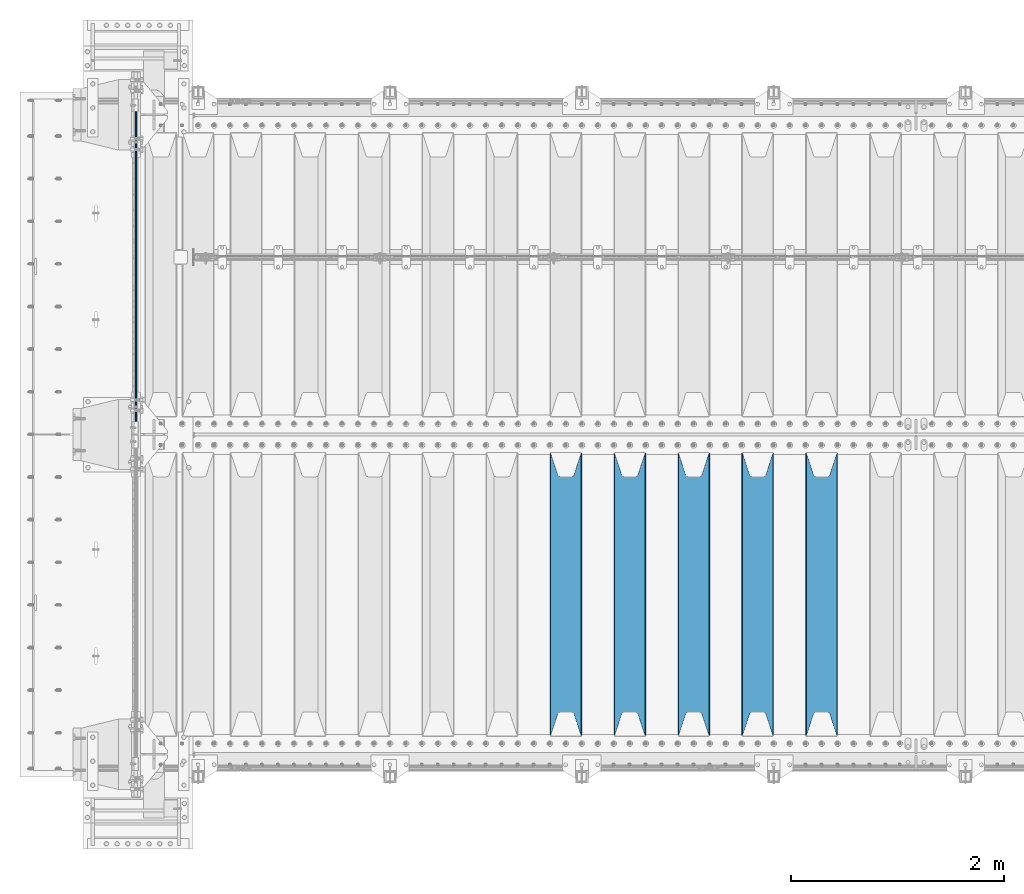
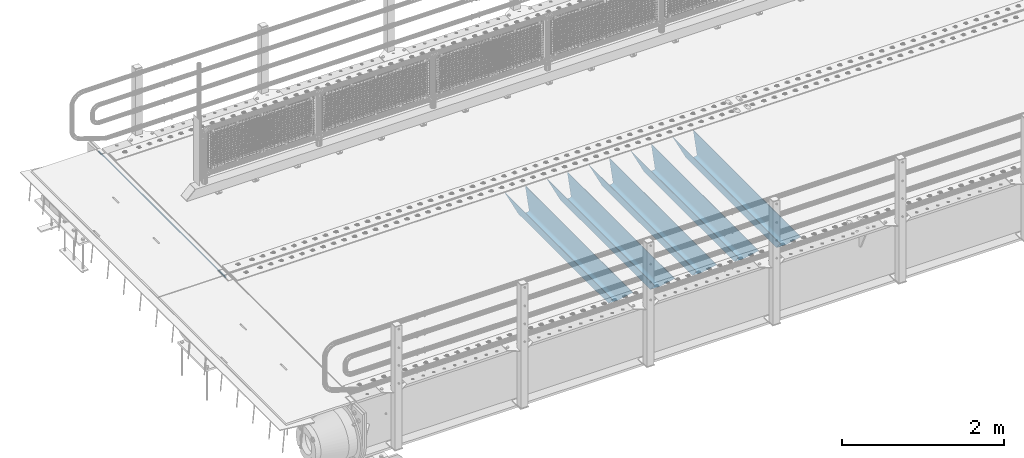
# One storey, part 112 of 242: 6 beams.
"""IFC2X3 building model written with IfcOpenShell, lengths in millimetres."""

from ifc_helpers import new_model, si_unit, frame, origin_with_axes, place, context, subcontext, project, spatial, faceted_brep, material, type_object, element, save


model = new_model("IFC2X3")

# Units and contexts
model_context = context("Model", 3, precision=1e-05, world=origin_with_axes())
body_context = subcontext(model_context, "Body", "Model", "MODEL_VIEW")
ifc_project = project(units=[si_unit("LENGTHUNIT", "METRE", prefix="MILLI"), si_unit("AREAUNIT", "SQUARE_METRE"), si_unit("VOLUMEUNIT", "CUBIC_METRE"), si_unit("MASSUNIT", "GRAM", prefix="KILO"), si_unit("TIMEUNIT", "SECOND"), si_unit("PLANEANGLEUNIT", "RADIAN"), si_unit("SOLIDANGLEUNIT", "STERADIAN"), si_unit("THERMODYNAMICTEMPERATUREUNIT", "DEGREE_CELSIUS"), si_unit("LUMINOUSINTENSITYUNIT", "LUMEN")], contexts=[model_context])

# Site, building, storey
site_placement = place(None, origin_with_axes())
site = spatial("IfcSite", under=ifc_project, at=site_placement, CompositionType="ELEMENT")
building_placement = place(site_placement, origin_with_axes())
building = spatial("IfcBuilding", under=site, at=building_placement, Name="Standard", CompositionType="ELEMENT")
storey_placement = place(building_placement, origin_with_axes())
storey = spatial("IfcBuildingStorey", under=building, at=storey_placement, Name="Undefined", CompositionType="ELEMENT", Elevation=0.0)

# Beams
ifc_material = material(Name="STEEL/S355N")
beam_type_1 = type_object("IfcBeamType", Name="D20", PredefinedType="NOTDEFINED")
beam_1_placement = place(storey_placement, frame((-42485.0, -20995.0, -25.9999999971316), z_axis=(0.0, 0.0, 1.0), x_axis=(0.0, 1.0, 0.0)))
element("IfcBeam", 1, at=beam_1_placement, inside=storey, type_object=beam_type_1, material=ifc_material, ObjectType="D20", context=body_context, shape_type="Brep", body=[
    faceted_brep([(0.0, -10.0, 0.0), (0.0, -7.07106781186303, -7.07106781186548), (3145.0, -7.07106781186303, -7.07106781186548), (3145.0, -10.0, 0.0), (0.0, 0.0, -10.0), (3145.0, 0.0, -10.0), (0.0, 7.07106781186303, -7.07106781186547), (3145.0, 7.07106781186303, -7.07106781186547), (0.0, 10.0, 0.0), (3145.0, 10.0, 0.0), (0.0, 7.07106781186303, 7.07106781186548), (3145.0, 7.07106781186303, 7.07106781186548), (0.0, 0.0, 10.0), (3145.0, 0.0, 10.0), (0.0, -7.07106781186303, 7.07106781186548), (3145.0, -7.07106781186303, 7.07106781186548)], [[[0, 1, 2, 3]], [[1, 4, 5, 2]], [[4, 6, 7, 5]], [[6, 8, 9, 7]], [[8, 10, 11, 9]], [[10, 12, 13, 11]], [[12, 14, 15, 13]], [[14, 0, 3, 15]], [[5, 7, 9, 11, 13, 15, 3, 2]], [[14, 12, 10, 8, 6, 4, 1, 0]]]),
])
beam_type_2 = type_object("IfcBeamType", PredefinedType="NOTDEFINED")
beam_2_placement = place(storey_placement, frame((-36050.0, -23825.0, -115.0), z_axis=(0.0, 0.0, 1.0), x_axis=(0.0, 1.0, 0.0)))
element("IfcBeam", 2, at=beam_2_placement, inside=storey, type_object=beam_type_2, material=ifc_material, context=body_context, shape_type="Brep", body=[
    faceted_brep([(0.0, 150.0, 115.0), (0.0, 143.689999999999, 115.0), (2650.00000000297, 143.689999999999, 115.0), (2650.00000000297, 150.0, 115.0), (2650.00000000297, 142.059565218402, 110.000000003099), (2650.00000000297, 148.369565218403, 110.000000003099), (2441.90079219209, -80.1103600731112, -98.0992078077845), (2437.7588105432, -77.5672621345584, -102.241189456673), (2434.06523489747, -74.4080125315522, -105.934765102404), (2430.91086095089, -70.710272125576, -109.089139048974), (2428.37322971128, -66.5649389910068, -111.626770288588), (2426.51472138055, -62.0739139532889, -113.485278619323), (2425.38102192092, -57.3475956567672, -114.618978078955), (2424.99999999987, -52.5021667386536, -115.0), (2424.99999999987, 52.5021667386536, -115.0), (2425.38102192092, 57.3475956567672, -114.618978078955), (2426.51472138055, 62.0739139532889, -113.485278619323), (2428.37322971128, 66.5649389910068, -111.626770288588), (2430.91086095089, 70.710272125576, -109.089139048974), (2434.06523489747, 74.4080125315522, -105.934765102404), (2437.7588105432, 77.5672621345584, -102.241189456673), (2441.90079219209, 80.1103600731112, -98.0992078077846), (2446.38936140511, 81.9747917625791, -93.6106385947584), (2448.2494850041, 76.2713538057251, -91.7505149957729), (2444.62967112262, 74.76777986261, -95.3703288772456), (2441.28936334126, 72.7168944282894, -98.710636658607), (2438.31067330438, 70.1691124903846, -101.689326695487), (2435.76682334747, 67.1870637758839, -104.233176652398), (2433.72034654133, 63.8440531834895, -106.279653458539), (2432.22154950042, 60.222258798236, -107.778450499454), (2431.30727574265, 56.4107117849089, -108.692724257221), (2430.99999999987, 52.5031078186876, -109.0), (2430.99999999987, -52.5031078186876, -109.0), (2431.30727574265, -56.4107117849089, -108.692724257221), (2432.22154950042, -60.222258798236, -107.778450499454), (2433.72034654133, -63.8440531834895, -106.279653458539), (2435.76682334747, -67.1870637758839, -104.233176652398), (2438.31067330438, -70.1691124903846, -101.689326695487), (2441.28936334126, -72.7168944282894, -98.7106366586071), (2444.62967112262, -74.76777986261, -95.3703288772457), (2448.2494850041, -76.2713538057251, -91.7505149957729), (2650.00000000297, -142.059565218402, 110.000000003099), (2650.00000000297, -148.369565218403, 110.000000003099), (2446.38936140511, -81.9747917625791, -93.6106385947584), (2650.00000000297, -143.689999999999, 115.0), (2650.00000000297, -150.0, 115.0), (0.0, -143.689999999999, 115.0), (0.0, -150.0, 115.0), (0.0, -148.369565218261, 110.000000002669), (203.610638597427, -81.9747917625791, -93.6106385947584), (208.099207810454, -80.1103600731112, -98.0992078077845), (212.241189459342, -77.5672621345584, -102.241189456673), (215.934765105074, -74.4080125315522, -105.934765102404), (219.089139051644, -70.710272125576, -109.089139048974), (221.626770291256, -66.5649389910068, -111.626770288588), (223.485278621993, -62.0739139532889, -113.485278619323), (224.618978081624, -57.3475956567672, -114.618978078955), (225.00000000267, -52.5021667386536, -115.0), (225.00000000267, 52.5021667386536, -115.0), (224.618978081624, 57.3475956567672, -114.618978078955), (223.485278621993, 62.0739139532889, -113.485278619323), (221.626770291256, 66.5649389910068, -111.626770288588), (219.089139051644, 70.710272125576, -109.089139048974), (215.934765105074, 74.4080125315522, -105.934765102404), (212.241189459342, 77.5672621345584, -102.241189456673), (208.099207810454, 80.1103600731112, -98.0992078077846), (203.610638597427, 81.9747917625791, -93.6106385947584), (0.0, 148.369565218261, 110.000000002669), (0.0, 142.05956521826, 110.000000002669), (201.750514998443, 76.2713538057251, -91.7505149957729), (205.370328879915, 74.76777986261, -95.3703288772456), (208.710636661275, 72.7168944282894, -98.710636658607), (211.689326698157, 70.1691124903846, -101.689326695487), (214.233176655067, 67.1870637758839, -104.233176652398), (216.279653461206, 63.8440531834895, -106.279653458539), (217.778450502123, 60.222258798236, -107.778450499454), (218.69272425989, 56.4107117849089, -108.692724257221), (219.00000000267, 52.5031078186876, -109.0), (219.00000000267, -52.5031078186876, -109.0), (218.69272425989, -56.4107117849089, -108.692724257221), (217.778450502123, -60.222258798236, -107.778450499454), (216.279653461206, -63.8440531834895, -106.279653458539), (214.233176655067, -67.1870637758839, -104.233176652398), (211.689326698157, -70.1691124903846, -101.689326695487), (208.710636661275, -72.7168944282894, -98.7106366586071), (205.370328879915, -74.76777986261, -95.3703288772457), (201.750514998443, -76.2713538057251, -91.7505149957729), (0.0, -142.05956521826, 110.000000002669)], [[[0, 1, 2, 3]], [[3, 2, 4, 5]], [[6, 7, 8, 9, 10, 11, 12, 13, 14, 15, 16, 17, 18, 19, 20, 21, 22, 5, 4, 23, 24, 25, 26, 27, 28, 29, 30, 31, 32, 33, 34, 35, 36, 37, 38, 39, 40, 41, 42, 43]], [[44, 45, 42, 41]], [[46, 47, 45, 44]], [[43, 42, 45, 47, 48, 49]], [[6, 43, 49, 50]], [[7, 6, 50, 51]], [[8, 7, 51, 52]], [[9, 8, 52, 53]], [[10, 9, 53, 54]], [[11, 10, 54, 55]], [[12, 11, 55, 56]], [[13, 12, 56, 57]], [[14, 13, 57, 58]], [[15, 14, 58, 59]], [[16, 15, 59, 60]], [[17, 16, 60, 61]], [[18, 17, 61, 62]], [[19, 18, 62, 63]], [[20, 19, 63, 64]], [[21, 20, 64, 65]], [[22, 21, 65, 66]], [[0, 3, 5, 22, 66, 67]], [[1, 0, 67, 68]], [[23, 4, 2, 1, 68, 69]], [[24, 23, 69, 70]], [[25, 24, 70, 71]], [[26, 25, 71, 72]], [[27, 26, 72, 73]], [[28, 27, 73, 74]], [[29, 28, 74, 75]], [[30, 29, 75, 76]], [[31, 30, 76, 77]], [[32, 31, 77, 78]], [[33, 32, 78, 79]], [[34, 33, 79, 80]], [[35, 34, 80, 81]], [[36, 35, 81, 82]], [[37, 36, 82, 83]], [[38, 37, 83, 84]], [[39, 38, 84, 85]], [[40, 39, 85, 86]], [[46, 44, 41, 40, 86, 87]], [[47, 46, 87, 48]], [[86, 85, 84, 83, 82, 81, 80, 79, 78, 77, 76, 75, 74, 73, 72, 71, 70, 69, 68, 67, 66, 65, 64, 63, 62, 61, 60, 59, 58, 57, 56, 55, 54, 53, 52, 51, 50, 49, 48, 87]]]),
])
beam_3_placement = place(storey_placement, frame((-36650.0, -23825.0, -115.0), z_axis=(0.0, 0.0, 1.0), x_axis=(0.0, 1.0, 0.0)))
element("IfcBeam", 3, at=beam_3_placement, inside=storey, type_object=beam_type_2, material=ifc_material, context=body_context, shape_type="Brep", body=[
    faceted_brep([(0.0, 150.0, 115.0), (0.0, 143.689999999999, 115.0), (2650.00000000297, 143.689999999999, 115.0), (2650.00000000297, 150.0, 115.0), (2650.00000000297, 142.059565218402, 110.000000003099), (2650.00000000297, 148.369565218403, 110.000000003099), (2441.90079219209, -80.1103600731112, -98.0992078077845), (2437.7588105432, -77.5672621345584, -102.241189456673), (2434.06523489747, -74.4080125315522, -105.934765102404), (2430.91086095089, -70.710272125576, -109.089139048974), (2428.37322971128, -66.5649389910068, -111.626770288588), (2426.51472138055, -62.0739139532889, -113.485278619323), (2425.38102192092, -57.3475956567672, -114.618978078955), (2424.99999999987, -52.5021667386536, -115.0), (2424.99999999987, 52.5021667386536, -115.0), (2425.38102192092, 57.3475956567672, -114.618978078955), (2426.51472138055, 62.0739139532889, -113.485278619323), (2428.37322971128, 66.5649389910068, -111.626770288588), (2430.91086095089, 70.710272125576, -109.089139048974), (2434.06523489747, 74.4080125315522, -105.934765102404), (2437.7588105432, 77.5672621345584, -102.241189456673), (2441.90079219209, 80.1103600731112, -98.0992078077846), (2446.38936140511, 81.9747917625791, -93.6106385947584), (2448.2494850041, 76.2713538057251, -91.7505149957729), (2444.62967112262, 74.76777986261, -95.3703288772456), (2441.28936334126, 72.7168944282894, -98.710636658607), (2438.31067330438, 70.1691124903846, -101.689326695487), (2435.76682334747, 67.1870637758839, -104.233176652398), (2433.72034654133, 63.8440531834895, -106.279653458539), (2432.22154950042, 60.222258798236, -107.778450499454), (2431.30727574265, 56.4107117849089, -108.692724257221), (2430.99999999987, 52.5031078186876, -109.0), (2430.99999999987, -52.5031078186876, -109.0), (2431.30727574265, -56.4107117849089, -108.692724257221), (2432.22154950042, -60.222258798236, -107.778450499454), (2433.72034654133, -63.8440531834895, -106.279653458539), (2435.76682334747, -67.1870637758839, -104.233176652398), (2438.31067330438, -70.1691124903846, -101.689326695487), (2441.28936334126, -72.7168944282894, -98.7106366586071), (2444.62967112262, -74.76777986261, -95.3703288772457), (2448.2494850041, -76.2713538057251, -91.7505149957729), (2650.00000000297, -142.059565218402, 110.000000003099), (2650.00000000297, -148.369565218403, 110.000000003099), (2446.38936140511, -81.9747917625791, -93.6106385947584), (2650.00000000297, -143.689999999999, 115.0), (2650.00000000297, -150.0, 115.0), (0.0, -143.689999999999, 115.0), (0.0, -150.0, 115.0), (0.0, -148.369565218261, 110.000000002669), (203.610638597427, -81.9747917625791, -93.6106385947584), (208.099207810454, -80.1103600731112, -98.0992078077845), (212.241189459342, -77.5672621345584, -102.241189456673), (215.934765105074, -74.4080125315522, -105.934765102404), (219.089139051644, -70.710272125576, -109.089139048974), (221.626770291256, -66.5649389910068, -111.626770288588), (223.485278621993, -62.0739139532889, -113.485278619323), (224.618978081624, -57.3475956567672, -114.618978078955), (225.00000000267, -52.5021667386536, -115.0), (225.00000000267, 52.5021667386536, -115.0), (224.618978081624, 57.3475956567672, -114.618978078955), (223.485278621993, 62.0739139532889, -113.485278619323), (221.626770291256, 66.5649389910068, -111.626770288588), (219.089139051644, 70.710272125576, -109.089139048974), (215.934765105074, 74.4080125315522, -105.934765102404), (212.241189459342, 77.5672621345584, -102.241189456673), (208.099207810454, 80.1103600731112, -98.0992078077846), (203.610638597427, 81.9747917625791, -93.6106385947584), (0.0, 148.369565218261, 110.000000002669), (0.0, 142.05956521826, 110.000000002669), (201.750514998443, 76.2713538057251, -91.7505149957729), (205.370328879915, 74.76777986261, -95.3703288772456), (208.710636661275, 72.7168944282894, -98.710636658607), (211.689326698157, 70.1691124903846, -101.689326695487), (214.233176655067, 67.1870637758839, -104.233176652398), (216.279653461206, 63.8440531834895, -106.279653458539), (217.778450502123, 60.222258798236, -107.778450499454), (218.69272425989, 56.4107117849089, -108.692724257221), (219.00000000267, 52.5031078186876, -109.0), (219.00000000267, -52.5031078186876, -109.0), (218.69272425989, -56.4107117849089, -108.692724257221), (217.778450502123, -60.222258798236, -107.778450499454), (216.279653461206, -63.8440531834895, -106.279653458539), (214.233176655067, -67.1870637758839, -104.233176652398), (211.689326698157, -70.1691124903846, -101.689326695487), (208.710636661275, -72.7168944282894, -98.7106366586071), (205.370328879915, -74.76777986261, -95.3703288772457), (201.750514998443, -76.2713538057251, -91.7505149957729), (0.0, -142.05956521826, 110.000000002669)], [[[0, 1, 2, 3]], [[3, 2, 4, 5]], [[6, 7, 8, 9, 10, 11, 12, 13, 14, 15, 16, 17, 18, 19, 20, 21, 22, 5, 4, 23, 24, 25, 26, 27, 28, 29, 30, 31, 32, 33, 34, 35, 36, 37, 38, 39, 40, 41, 42, 43]], [[44, 45, 42, 41]], [[46, 47, 45, 44]], [[43, 42, 45, 47, 48, 49]], [[6, 43, 49, 50]], [[7, 6, 50, 51]], [[8, 7, 51, 52]], [[9, 8, 52, 53]], [[10, 9, 53, 54]], [[11, 10, 54, 55]], [[12, 11, 55, 56]], [[13, 12, 56, 57]], [[14, 13, 57, 58]], [[15, 14, 58, 59]], [[16, 15, 59, 60]], [[17, 16, 60, 61]], [[18, 17, 61, 62]], [[19, 18, 62, 63]], [[20, 19, 63, 64]], [[21, 20, 64, 65]], [[22, 21, 65, 66]], [[0, 3, 5, 22, 66, 67]], [[1, 0, 67, 68]], [[23, 4, 2, 1, 68, 69]], [[24, 23, 69, 70]], [[25, 24, 70, 71]], [[26, 25, 71, 72]], [[27, 26, 72, 73]], [[28, 27, 73, 74]], [[29, 28, 74, 75]], [[30, 29, 75, 76]], [[31, 30, 76, 77]], [[32, 31, 77, 78]], [[33, 32, 78, 79]], [[34, 33, 79, 80]], [[35, 34, 80, 81]], [[36, 35, 81, 82]], [[37, 36, 82, 83]], [[38, 37, 83, 84]], [[39, 38, 84, 85]], [[40, 39, 85, 86]], [[46, 44, 41, 40, 86, 87]], [[47, 46, 87, 48]], [[86, 85, 84, 83, 82, 81, 80, 79, 78, 77, 76, 75, 74, 73, 72, 71, 70, 69, 68, 67, 66, 65, 64, 63, 62, 61, 60, 59, 58, 57, 56, 55, 54, 53, 52, 51, 50, 49, 48, 87]]]),
])
beam_4_placement = place(storey_placement, frame((-37250.0, -23825.0, -115.0), z_axis=(0.0, 0.0, 1.0), x_axis=(0.0, 1.0, 0.0)))
element("IfcBeam", 4, at=beam_4_placement, inside=storey, type_object=beam_type_2, material=ifc_material, context=body_context, shape_type="Brep", body=[
    faceted_brep([(0.0, 150.0, 115.0), (0.0, 143.689999999999, 115.0), (2650.00000000297, 143.689999999999, 115.0), (2650.00000000297, 150.0, 115.0), (2650.00000000297, 142.059565218402, 110.000000003099), (2650.00000000297, 148.369565218403, 110.000000003099), (2441.90079219209, -80.1103600731112, -98.0992078077845), (2437.7588105432, -77.5672621345584, -102.241189456673), (2434.06523489747, -74.4080125315522, -105.934765102404), (2430.91086095089, -70.710272125576, -109.089139048974), (2428.37322971128, -66.5649389910068, -111.626770288588), (2426.51472138055, -62.0739139532889, -113.485278619323), (2425.38102192092, -57.3475956567672, -114.618978078955), (2424.99999999987, -52.5021667386536, -115.0), (2424.99999999987, 52.5021667386536, -115.0), (2425.38102192092, 57.3475956567672, -114.618978078955), (2426.51472138055, 62.0739139532889, -113.485278619323), (2428.37322971128, 66.5649389910068, -111.626770288588), (2430.91086095089, 70.710272125576, -109.089139048974), (2434.06523489747, 74.4080125315522, -105.934765102404), (2437.7588105432, 77.5672621345584, -102.241189456673), (2441.90079219209, 80.1103600731112, -98.0992078077846), (2446.38936140511, 81.9747917625791, -93.6106385947584), (2448.2494850041, 76.2713538057251, -91.7505149957729), (2444.62967112262, 74.76777986261, -95.3703288772456), (2441.28936334126, 72.7168944282894, -98.710636658607), (2438.31067330438, 70.1691124903846, -101.689326695487), (2435.76682334747, 67.1870637758839, -104.233176652398), (2433.72034654133, 63.8440531834895, -106.279653458539), (2432.22154950042, 60.222258798236, -107.778450499454), (2431.30727574265, 56.4107117849089, -108.692724257221), (2430.99999999987, 52.5031078186876, -109.0), (2430.99999999987, -52.5031078186876, -109.0), (2431.30727574265, -56.4107117849089, -108.692724257221), (2432.22154950042, -60.222258798236, -107.778450499454), (2433.72034654133, -63.8440531834895, -106.279653458539), (2435.76682334747, -67.1870637758839, -104.233176652398), (2438.31067330438, -70.1691124903846, -101.689326695487), (2441.28936334126, -72.7168944282894, -98.7106366586071), (2444.62967112262, -74.76777986261, -95.3703288772457), (2448.2494850041, -76.2713538057251, -91.7505149957729), (2650.00000000297, -142.059565218402, 110.000000003099), (2650.00000000297, -148.369565218403, 110.000000003099), (2446.38936140511, -81.9747917625791, -93.6106385947584), (2650.00000000297, -143.689999999999, 115.0), (2650.00000000297, -150.0, 115.0), (0.0, -143.689999999999, 115.0), (0.0, -150.0, 115.0), (0.0, -148.369565218261, 110.000000002669), (203.610638597427, -81.9747917625791, -93.6106385947584), (208.099207810454, -80.1103600731112, -98.0992078077845), (212.241189459342, -77.5672621345584, -102.241189456673), (215.934765105074, -74.4080125315522, -105.934765102404), (219.089139051644, -70.710272125576, -109.089139048974), (221.626770291256, -66.5649389910068, -111.626770288588), (223.485278621993, -62.0739139532889, -113.485278619323), (224.618978081624, -57.3475956567672, -114.618978078955), (225.00000000267, -52.5021667386536, -115.0), (225.00000000267, 52.5021667386536, -115.0), (224.618978081624, 57.3475956567672, -114.618978078955), (223.485278621993, 62.0739139532889, -113.485278619323), (221.626770291256, 66.5649389910068, -111.626770288588), (219.089139051644, 70.710272125576, -109.089139048974), (215.934765105074, 74.4080125315522, -105.934765102404), (212.241189459342, 77.5672621345584, -102.241189456673), (208.099207810454, 80.1103600731112, -98.0992078077846), (203.610638597427, 81.9747917625791, -93.6106385947584), (0.0, 148.369565218261, 110.000000002669), (0.0, 142.05956521826, 110.000000002669), (201.750514998443, 76.2713538057251, -91.7505149957729), (205.370328879915, 74.76777986261, -95.3703288772456), (208.710636661275, 72.7168944282894, -98.710636658607), (211.689326698157, 70.1691124903846, -101.689326695487), (214.233176655067, 67.1870637758839, -104.233176652398), (216.279653461206, 63.8440531834895, -106.279653458539), (217.778450502123, 60.222258798236, -107.778450499454), (218.69272425989, 56.4107117849089, -108.692724257221), (219.00000000267, 52.5031078186876, -109.0), (219.00000000267, -52.5031078186876, -109.0), (218.69272425989, -56.4107117849089, -108.692724257221), (217.778450502123, -60.222258798236, -107.778450499454), (216.279653461206, -63.8440531834895, -106.279653458539), (214.233176655067, -67.1870637758839, -104.233176652398), (211.689326698157, -70.1691124903846, -101.689326695487), (208.710636661275, -72.7168944282894, -98.7106366586071), (205.370328879915, -74.76777986261, -95.3703288772457), (201.750514998443, -76.2713538057251, -91.7505149957729), (0.0, -142.05956521826, 110.000000002669)], [[[0, 1, 2, 3]], [[3, 2, 4, 5]], [[6, 7, 8, 9, 10, 11, 12, 13, 14, 15, 16, 17, 18, 19, 20, 21, 22, 5, 4, 23, 24, 25, 26, 27, 28, 29, 30, 31, 32, 33, 34, 35, 36, 37, 38, 39, 40, 41, 42, 43]], [[44, 45, 42, 41]], [[46, 47, 45, 44]], [[43, 42, 45, 47, 48, 49]], [[6, 43, 49, 50]], [[7, 6, 50, 51]], [[8, 7, 51, 52]], [[9, 8, 52, 53]], [[10, 9, 53, 54]], [[11, 10, 54, 55]], [[12, 11, 55, 56]], [[13, 12, 56, 57]], [[14, 13, 57, 58]], [[15, 14, 58, 59]], [[16, 15, 59, 60]], [[17, 16, 60, 61]], [[18, 17, 61, 62]], [[19, 18, 62, 63]], [[20, 19, 63, 64]], [[21, 20, 64, 65]], [[22, 21, 65, 66]], [[0, 3, 5, 22, 66, 67]], [[1, 0, 67, 68]], [[23, 4, 2, 1, 68, 69]], [[24, 23, 69, 70]], [[25, 24, 70, 71]], [[26, 25, 71, 72]], [[27, 26, 72, 73]], [[28, 27, 73, 74]], [[29, 28, 74, 75]], [[30, 29, 75, 76]], [[31, 30, 76, 77]], [[32, 31, 77, 78]], [[33, 32, 78, 79]], [[34, 33, 79, 80]], [[35, 34, 80, 81]], [[36, 35, 81, 82]], [[37, 36, 82, 83]], [[38, 37, 83, 84]], [[39, 38, 84, 85]], [[40, 39, 85, 86]], [[46, 44, 41, 40, 86, 87]], [[47, 46, 87, 48]], [[86, 85, 84, 83, 82, 81, 80, 79, 78, 77, 76, 75, 74, 73, 72, 71, 70, 69, 68, 67, 66, 65, 64, 63, 62, 61, 60, 59, 58, 57, 56, 55, 54, 53, 52, 51, 50, 49, 48, 87]]]),
])
beam_5_placement = place(storey_placement, frame((-37850.0, -23825.0, -115.0), z_axis=(0.0, 0.0, 1.0), x_axis=(0.0, 1.0, 0.0)))
element("IfcBeam", 5, at=beam_5_placement, inside=storey, type_object=beam_type_2, material=ifc_material, context=body_context, shape_type="Brep", body=[
    faceted_brep([(0.0, 150.0, 115.0), (0.0, 143.689999999999, 115.0), (2650.00000000297, 143.689999999999, 115.0), (2650.00000000297, 150.0, 115.0), (2650.00000000297, 142.059565218402, 110.000000003099), (2650.00000000297, 148.369565218403, 110.000000003099), (2441.90079219209, -80.1103600731112, -98.0992078077845), (2437.7588105432, -77.5672621345584, -102.241189456673), (2434.06523489747, -74.4080125315522, -105.934765102404), (2430.91086095089, -70.710272125576, -109.089139048974), (2428.37322971128, -66.5649389910068, -111.626770288588), (2426.51472138055, -62.0739139532889, -113.485278619323), (2425.38102192092, -57.3475956567672, -114.618978078955), (2424.99999999987, -52.5021667386536, -115.0), (2424.99999999987, 52.5021667386536, -115.0), (2425.38102192092, 57.3475956567672, -114.618978078955), (2426.51472138055, 62.0739139532889, -113.485278619323), (2428.37322971128, 66.5649389910068, -111.626770288588), (2430.91086095089, 70.710272125576, -109.089139048974), (2434.06523489747, 74.4080125315522, -105.934765102404), (2437.7588105432, 77.5672621345584, -102.241189456673), (2441.90079219209, 80.1103600731112, -98.0992078077846), (2446.38936140511, 81.9747917625791, -93.6106385947584), (2448.2494850041, 76.2713538057251, -91.7505149957729), (2444.62967112262, 74.76777986261, -95.3703288772456), (2441.28936334126, 72.7168944282894, -98.710636658607), (2438.31067330438, 70.1691124903846, -101.689326695487), (2435.76682334747, 67.1870637758839, -104.233176652398), (2433.72034654133, 63.8440531834895, -106.279653458539), (2432.22154950042, 60.222258798236, -107.778450499454), (2431.30727574265, 56.4107117849089, -108.692724257221), (2430.99999999987, 52.5031078186876, -109.0), (2430.99999999987, -52.5031078186876, -109.0), (2431.30727574265, -56.4107117849089, -108.692724257221), (2432.22154950042, -60.222258798236, -107.778450499454), (2433.72034654133, -63.8440531834895, -106.279653458539), (2435.76682334747, -67.1870637758839, -104.233176652398), (2438.31067330438, -70.1691124903846, -101.689326695487), (2441.28936334126, -72.7168944282894, -98.7106366586071), (2444.62967112262, -74.76777986261, -95.3703288772457), (2448.2494850041, -76.2713538057251, -91.7505149957729), (2650.00000000297, -142.059565218402, 110.000000003099), (2650.00000000297, -148.369565218403, 110.000000003099), (2446.38936140511, -81.9747917625791, -93.6106385947584), (2650.00000000297, -143.689999999999, 115.0), (2650.00000000297, -150.0, 115.0), (0.0, -143.689999999999, 115.0), (0.0, -150.0, 115.0), (0.0, -148.369565218261, 110.000000002669), (203.610638597427, -81.9747917625791, -93.6106385947584), (208.099207810454, -80.1103600731112, -98.0992078077845), (212.241189459342, -77.5672621345584, -102.241189456673), (215.934765105074, -74.4080125315522, -105.934765102404), (219.089139051644, -70.710272125576, -109.089139048974), (221.626770291256, -66.5649389910068, -111.626770288588), (223.485278621993, -62.0739139532889, -113.485278619323), (224.618978081624, -57.3475956567672, -114.618978078955), (225.00000000267, -52.5021667386536, -115.0), (225.00000000267, 52.5021667386536, -115.0), (224.618978081624, 57.3475956567672, -114.618978078955), (223.485278621993, 62.0739139532889, -113.485278619323), (221.626770291256, 66.5649389910068, -111.626770288588), (219.089139051644, 70.710272125576, -109.089139048974), (215.934765105074, 74.4080125315522, -105.934765102404), (212.241189459342, 77.5672621345584, -102.241189456673), (208.099207810454, 80.1103600731112, -98.0992078077846), (203.610638597427, 81.9747917625791, -93.6106385947584), (0.0, 148.369565218261, 110.000000002669), (0.0, 142.05956521826, 110.000000002669), (201.750514998443, 76.2713538057251, -91.7505149957729), (205.370328879915, 74.76777986261, -95.3703288772456), (208.710636661275, 72.7168944282894, -98.710636658607), (211.689326698157, 70.1691124903846, -101.689326695487), (214.233176655067, 67.1870637758839, -104.233176652398), (216.279653461206, 63.8440531834895, -106.279653458539), (217.778450502123, 60.222258798236, -107.778450499454), (218.69272425989, 56.4107117849089, -108.692724257221), (219.00000000267, 52.5031078186876, -109.0), (219.00000000267, -52.5031078186876, -109.0), (218.69272425989, -56.4107117849089, -108.692724257221), (217.778450502123, -60.222258798236, -107.778450499454), (216.279653461206, -63.8440531834895, -106.279653458539), (214.233176655067, -67.1870637758839, -104.233176652398), (211.689326698157, -70.1691124903846, -101.689326695487), (208.710636661275, -72.7168944282894, -98.7106366586071), (205.370328879915, -74.76777986261, -95.3703288772457), (201.750514998443, -76.2713538057251, -91.7505149957729), (0.0, -142.05956521826, 110.000000002669)], [[[0, 1, 2, 3]], [[3, 2, 4, 5]], [[6, 7, 8, 9, 10, 11, 12, 13, 14, 15, 16, 17, 18, 19, 20, 21, 22, 5, 4, 23, 24, 25, 26, 27, 28, 29, 30, 31, 32, 33, 34, 35, 36, 37, 38, 39, 40, 41, 42, 43]], [[44, 45, 42, 41]], [[46, 47, 45, 44]], [[43, 42, 45, 47, 48, 49]], [[6, 43, 49, 50]], [[7, 6, 50, 51]], [[8, 7, 51, 52]], [[9, 8, 52, 53]], [[10, 9, 53, 54]], [[11, 10, 54, 55]], [[12, 11, 55, 56]], [[13, 12, 56, 57]], [[14, 13, 57, 58]], [[15, 14, 58, 59]], [[16, 15, 59, 60]], [[17, 16, 60, 61]], [[18, 17, 61, 62]], [[19, 18, 62, 63]], [[20, 19, 63, 64]], [[21, 20, 64, 65]], [[22, 21, 65, 66]], [[0, 3, 5, 22, 66, 67]], [[1, 0, 67, 68]], [[23, 4, 2, 1, 68, 69]], [[24, 23, 69, 70]], [[25, 24, 70, 71]], [[26, 25, 71, 72]], [[27, 26, 72, 73]], [[28, 27, 73, 74]], [[29, 28, 74, 75]], [[30, 29, 75, 76]], [[31, 30, 76, 77]], [[32, 31, 77, 78]], [[33, 32, 78, 79]], [[34, 33, 79, 80]], [[35, 34, 80, 81]], [[36, 35, 81, 82]], [[37, 36, 82, 83]], [[38, 37, 83, 84]], [[39, 38, 84, 85]], [[40, 39, 85, 86]], [[46, 44, 41, 40, 86, 87]], [[47, 46, 87, 48]], [[86, 85, 84, 83, 82, 81, 80, 79, 78, 77, 76, 75, 74, 73, 72, 71, 70, 69, 68, 67, 66, 65, 64, 63, 62, 61, 60, 59, 58, 57, 56, 55, 54, 53, 52, 51, 50, 49, 48, 87]]]),
])
beam_6_placement = place(storey_placement, frame((-38450.0, -23825.0, -115.0), z_axis=(0.0, 0.0, 1.0), x_axis=(0.0, 1.0, 0.0)))
element("IfcBeam", 6, at=beam_6_placement, inside=storey, type_object=beam_type_2, material=ifc_material, context=body_context, shape_type="Brep", body=[
    faceted_brep([(0.0, 150.0, 115.0), (0.0, 143.689999999999, 115.0), (2650.00000000297, 143.689999999999, 115.0), (2650.00000000297, 150.0, 115.0), (2650.00000000297, 142.059565218402, 110.000000003099), (2650.00000000297, 148.369565218403, 110.000000003099), (2441.90079219209, -80.1103600731112, -98.0992078077845), (2437.7588105432, -77.5672621345584, -102.241189456673), (2434.06523489747, -74.4080125315522, -105.934765102404), (2430.91086095089, -70.710272125576, -109.089139048974), (2428.37322971128, -66.5649389910068, -111.626770288588), (2426.51472138055, -62.0739139532889, -113.485278619323), (2425.38102192092, -57.3475956567672, -114.618978078955), (2424.99999999987, -52.5021667386536, -115.0), (2424.99999999987, 52.5021667386536, -115.0), (2425.38102192092, 57.3475956567672, -114.618978078955), (2426.51472138055, 62.0739139532889, -113.485278619323), (2428.37322971128, 66.5649389910068, -111.626770288588), (2430.91086095089, 70.710272125576, -109.089139048974), (2434.06523489747, 74.4080125315522, -105.934765102404), (2437.7588105432, 77.5672621345584, -102.241189456673), (2441.90079219209, 80.1103600731112, -98.0992078077846), (2446.38936140511, 81.9747917625791, -93.6106385947584), (2448.2494850041, 76.2713538057251, -91.7505149957729), (2444.62967112262, 74.76777986261, -95.3703288772456), (2441.28936334126, 72.7168944282894, -98.710636658607), (2438.31067330438, 70.1691124903846, -101.689326695487), (2435.76682334747, 67.1870637758839, -104.233176652398), (2433.72034654133, 63.8440531834895, -106.279653458539), (2432.22154950042, 60.222258798236, -107.778450499454), (2431.30727574265, 56.4107117849089, -108.692724257221), (2430.99999999987, 52.5031078186876, -109.0), (2430.99999999987, -52.5031078186876, -109.0), (2431.30727574265, -56.4107117849089, -108.692724257221), (2432.22154950042, -60.222258798236, -107.778450499454), (2433.72034654133, -63.8440531834895, -106.279653458539), (2435.76682334747, -67.1870637758839, -104.233176652398), (2438.31067330438, -70.1691124903846, -101.689326695487), (2441.28936334126, -72.7168944282894, -98.7106366586071), (2444.62967112262, -74.76777986261, -95.3703288772457), (2448.2494850041, -76.2713538057251, -91.7505149957729), (2650.00000000297, -142.059565218402, 110.000000003099), (2650.00000000297, -148.369565218403, 110.000000003099), (2446.38936140511, -81.9747917625791, -93.6106385947584), (2650.00000000297, -143.689999999999, 115.0), (2650.00000000297, -150.0, 115.0), (0.0, -143.689999999999, 115.0), (0.0, -150.0, 115.0), (0.0, -148.369565218261, 110.000000002669), (203.610638597427, -81.9747917625791, -93.6106385947584), (208.099207810454, -80.1103600731112, -98.0992078077845), (212.241189459342, -77.5672621345584, -102.241189456673), (215.934765105074, -74.4080125315522, -105.934765102404), (219.089139051644, -70.710272125576, -109.089139048974), (221.626770291256, -66.5649389910068, -111.626770288588), (223.485278621993, -62.0739139532889, -113.485278619323), (224.618978081624, -57.3475956567672, -114.618978078955), (225.00000000267, -52.5021667386536, -115.0), (225.00000000267, 52.5021667386536, -115.0), (224.618978081624, 57.3475956567672, -114.618978078955), (223.485278621993, 62.0739139532889, -113.485278619323), (221.626770291256, 66.5649389910068, -111.626770288588), (219.089139051644, 70.710272125576, -109.089139048974), (215.934765105074, 74.4080125315522, -105.934765102404), (212.241189459342, 77.5672621345584, -102.241189456673), (208.099207810454, 80.1103600731112, -98.0992078077846), (203.610638597427, 81.9747917625791, -93.6106385947584), (0.0, 148.369565218261, 110.000000002669), (0.0, 142.05956521826, 110.000000002669), (201.750514998443, 76.2713538057251, -91.7505149957729), (205.370328879915, 74.76777986261, -95.3703288772456), (208.710636661275, 72.7168944282894, -98.710636658607), (211.689326698157, 70.1691124903846, -101.689326695487), (214.233176655067, 67.1870637758839, -104.233176652398), (216.279653461206, 63.8440531834895, -106.279653458539), (217.778450502123, 60.222258798236, -107.778450499454), (218.69272425989, 56.4107117849089, -108.692724257221), (219.00000000267, 52.5031078186876, -109.0), (219.00000000267, -52.5031078186876, -109.0), (218.69272425989, -56.4107117849089, -108.692724257221), (217.778450502123, -60.222258798236, -107.778450499454), (216.279653461206, -63.8440531834895, -106.279653458539), (214.233176655067, -67.1870637758839, -104.233176652398), (211.689326698157, -70.1691124903846, -101.689326695487), (208.710636661275, -72.7168944282894, -98.7106366586071), (205.370328879915, -74.76777986261, -95.3703288772457), (201.750514998443, -76.2713538057251, -91.7505149957729), (0.0, -142.05956521826, 110.000000002669)], [[[0, 1, 2, 3]], [[3, 2, 4, 5]], [[6, 7, 8, 9, 10, 11, 12, 13, 14, 15, 16, 17, 18, 19, 20, 21, 22, 5, 4, 23, 24, 25, 26, 27, 28, 29, 30, 31, 32, 33, 34, 35, 36, 37, 38, 39, 40, 41, 42, 43]], [[44, 45, 42, 41]], [[46, 47, 45, 44]], [[43, 42, 45, 47, 48, 49]], [[6, 43, 49, 50]], [[7, 6, 50, 51]], [[8, 7, 51, 52]], [[9, 8, 52, 53]], [[10, 9, 53, 54]], [[11, 10, 54, 55]], [[12, 11, 55, 56]], [[13, 12, 56, 57]], [[14, 13, 57, 58]], [[15, 14, 58, 59]], [[16, 15, 59, 60]], [[17, 16, 60, 61]], [[18, 17, 61, 62]], [[19, 18, 62, 63]], [[20, 19, 63, 64]], [[21, 20, 64, 65]], [[22, 21, 65, 66]], [[0, 3, 5, 22, 66, 67]], [[1, 0, 67, 68]], [[23, 4, 2, 1, 68, 69]], [[24, 23, 69, 70]], [[25, 24, 70, 71]], [[26, 25, 71, 72]], [[27, 26, 72, 73]], [[28, 27, 73, 74]], [[29, 28, 74, 75]], [[30, 29, 75, 76]], [[31, 30, 76, 77]], [[32, 31, 77, 78]], [[33, 32, 78, 79]], [[34, 33, 79, 80]], [[35, 34, 80, 81]], [[36, 35, 81, 82]], [[37, 36, 82, 83]], [[38, 37, 83, 84]], [[39, 38, 84, 85]], [[40, 39, 85, 86]], [[46, 44, 41, 40, 86, 87]], [[47, 46, 87, 48]], [[86, 85, 84, 83, 82, 81, 80, 79, 78, 77, 76, 75, 74, 73, 72, 71, 70, 69, 68, 67, 66, 65, 64, 63, 62, 61, 60, 59, 58, 57, 56, 55, 54, 53, 52, 51, 50, 49, 48, 87]]]),
])

save(model, "model.ifc")
